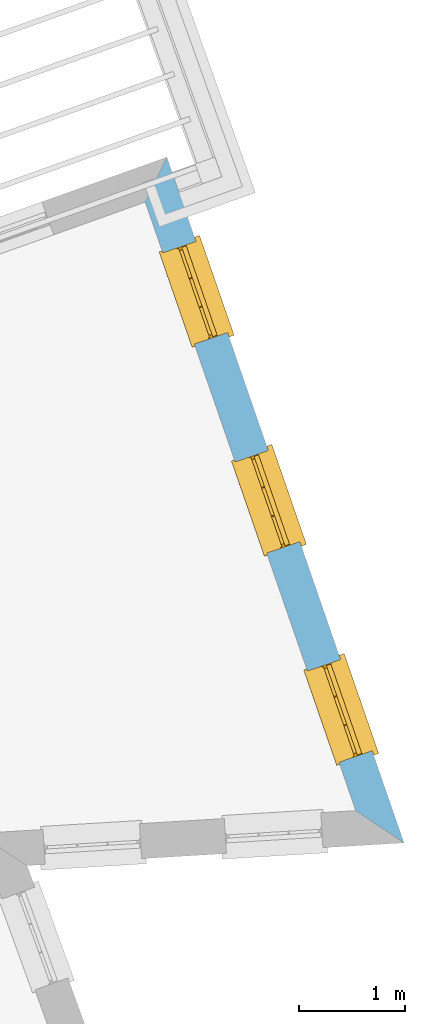
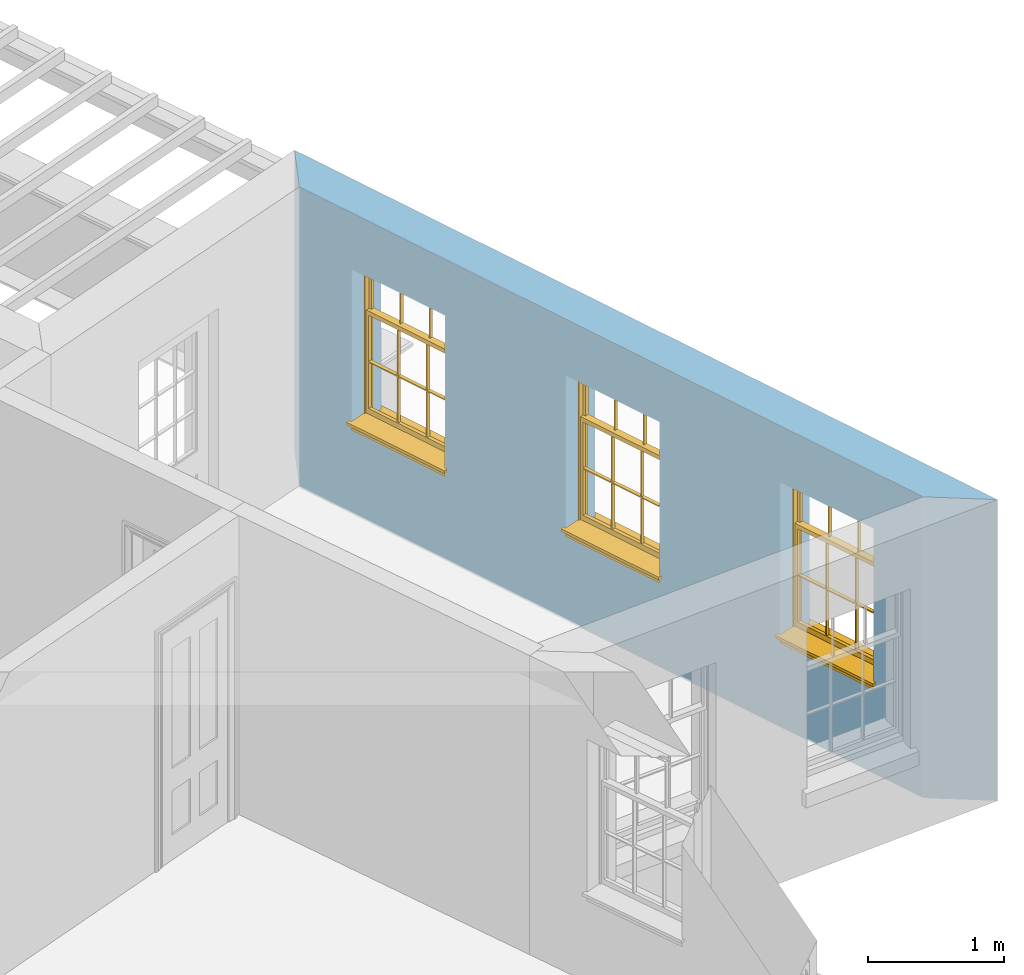
# One storey, part 7 of 12: 3 windows, 3 openings, plus 1 element that does not belong to this part.
"""IFC2X3 building model written with IfcOpenShell, lengths in metres."""

from ifc_helpers import new_model, si_unit, frame, origin, place, context, subcontext, project, spatial, polyline, outline, extrude, faceted_brep, material, layer, layer_set, layer_usage, element, fill, save


model = new_model("IFC2X3")

# Units and contexts
model_context = context("Model", 3, world=origin())
body_context = subcontext(model_context, "Body", "Model", "MODEL_VIEW")
ifc_project = project(units=[si_unit("PLANEANGLEUNIT", "RADIAN"), si_unit("MASSUNIT", "GRAM", prefix="KILO"), si_unit("FORCEUNIT", "NEWTON", prefix="KILO"), si_unit("LENGTHUNIT", "METRE")], contexts=[model_context])

# Site, building, storey
site_placement = place(None, origin())
site = spatial("IfcSite", under=ifc_project, at=site_placement, CompositionType="ELEMENT")
building_placement = place(None, origin())
building = spatial("IfcBuilding", under=site, at=building_placement, Name="Building plot-12", CompositionType="ELEMENT")
storey_placement = place(None, frame((0.0, 0.0, 6.45)))
storey = spatial("IfcBuildingStorey", under=building, at=storey_placement, Name="Floor 1", CompositionType="ELEMENT", Elevation=6.45)

# Wall, openings, windows
ifc_material = material(Name="Masonry")
ifc_layer = layer(ifc_material, 0.33, ventilated=False)
ifc_layer_set = layer_set([ifc_layer], Name="My Wall")
ifc_layer_usage = layer_usage(ifc_layer_set, "AXIS2", "NEGATIVE", 0.08)
wall_placement = place(storey_placement, origin())
wall = element("IfcWallStandardCase", 1, at=wall_placement, inside=storey, material=ifc_layer_usage, Name="exterior", context=body_context, shape_type="SweptSolid", body=[
    extrude(outline(polyline([(62.6036094343713, 35.0733568984167), (63.057647216937, 34.7701593682112), (60.8252944529976, 41.2249256313146), (60.6224114250311, 40.801918386454), (62.6036094343713, 35.0733568984167)])), origin(), (0.0, 0.0, 1.0), 2.7),
])
opening_1_placement = place(storey_placement, frame((0.0, 0.0, 0.75)))
opening_1 = element("IfcOpeningElement", 2, at=opening_1_placement, cuts=wall, Name="Opening", ObjectType="Opening", context=body_context, shape_type="SweptSolid", body=[
    extrude(outline(polyline([(62.7583178339086, 35.6356593171161), (62.4608839337952, 36.4956785465891), (62.1490088286017, 36.387817901493), (62.4464427287151, 35.52779867202), (62.7583178339086, 35.6356593171161)])), origin(), (0.0, 0.0, 1.0), 1.445),
])
opening_2_placement = place(storey_placement, frame((0.0, 0.0, 0.75)))
opening_2 = element("IfcOpeningElement", 3, at=opening_2_placement, cuts=wall, Name="Opening", ObjectType="Opening", context=body_context, shape_type="SweptSolid", body=[
    extrude(outline(polyline([(62.0776231637569, 37.6038630272753), (61.7801892636435, 38.4638822567483), (61.46831415845, 38.3560216116522), (61.7657480585634, 37.4960023821792), (62.0776231637569, 37.6038630272753)])), origin(), (0.0, 0.0, 1.0), 1.445),
])
opening_3_placement = place(storey_placement, frame((0.0, 0.0, 0.75)))
opening_3 = element("IfcOpeningElement", 4, at=opening_3_placement, cuts=wall, Name="Opening", ObjectType="Opening", context=body_context, shape_type="SweptSolid", body=[
    extrude(outline(polyline([(61.3969284936051, 39.5720667374345), (61.0994945934918, 40.4320859669075), (60.7876194882983, 40.3242253218114), (61.0850533884116, 39.4642060923384), (61.3969284936051, 39.5720667374345)])), origin(), (0.0, 0.0, 1.0), 1.445),
])
window_1_placement = place(storey_placement, frame((62.5220488148226, 35.5539467071948, 0.75), z_axis=(0.0, 0.0, 1.0), x_axis=(-0.297433900113383, 0.860019229473011, 0.0)))
window_1 = element("IfcWindow", 5, at=window_1_placement, inside=storey, Name="bedroom outside window", OverallHeight=1.445, OverallWidth=0.91, context=body_context, shape_type="Brep", held_by="IfcProductRepresentation", body=[
    faceted_brep([(0.876875, -0.105, 0.999097), (0.876875, -0.105, 1.411875), (0.9, -0.105, 1.435), (0.033125, -0.105, 1.411875), (0.033125, -0.105, 0.999097), (0.01, -0.105, 1.435), (0.033125, -0.135, 1.411875), (0.01, -0.135, 1.435), (0.033125, -0.135, 0.999097), (0.876875, -0.135, 1.411875), (0.876875, -0.135, 0.999097), (0.9, -0.135, 1.435), (0.033125, -0.105, 0.960972), (0.01, -0.105, 0.960972), (0.033125, -0.105, 0.548195), (0.876875, -0.105, 0.960972), (0.876875, -0.105, 0.548195), (0.9, -0.105, 0.960972), (0.876875, -0.105, 0.538195), (0.876875, -0.105, 0.125417), (0.9, -0.105, 0.077167), (0.033125, -0.105, 0.125417), (0.033125, -0.105, 0.538195), (0.01, -0.105, 0.077167), (0.9, -0.135, 0.960972), (0.01, -0.135, 0.960972), (-0.0425, -0.25, 0.01), (-0.0425, -0.3, 0.001667), (0.0, -0.25, 0.01), (0.9525, -0.25, 0.01), (0.91, -0.25, 0.01), (0.9525, -0.3, 0.001667), (-0.02, 0.08, 0.077167), (0.0, 0.08, 0.077167), (-0.02, 0.11, 0.077167), (0.0, -0.06, 0.077167), (0.01, -0.06, 0.077167), (0.91, -0.06, 0.077167), (0.91, 0.08, 0.077167), (0.9, -0.06, 0.077167), (0.93, 0.08, 0.077167), (0.93, 0.11, 0.077167), (0.01, -0.105, 0.999097), (0.01, -0.075, 0.999097), (0.9, -0.105, 0.999097), (0.9, -0.075, 0.999097), (0.876875, -0.075, 0.125417), (0.876875, -0.075, 0.538195), (0.9, -0.075, 0.077167), (0.876875, -0.075, 0.548195), (0.876875, -0.075, 0.960972), (0.033125, -0.075, 0.125417), (0.01, -0.075, 0.077167), (0.033125, -0.075, 0.538195), (0.033125, -0.075, 0.960972), (0.033125, -0.075, 0.548195), (-0.02, 0.08, 0.052167), (-0.02, 0.11, 0.052167), (0.93, 0.11, 0.052167), (0.93, 0.08, 0.052167), (0.91, 0.08, 0.052167), (0.0, 0.08, 0.052167), (0.91, -0.15, 0.026667), (0.0, -0.15, 0.026667), (-0.0425, -0.3, -0.123333), (0.9525, -0.3, -0.123333), (-0.0425, -0.25, -0.123333), (0.9525, -0.25, -0.123333), (0.01, -0.06, 1.435), (0.9, -0.06, 1.435), (0.0, -0.06, 1.445), (0.91, -0.06, 1.445), (0.01, -0.15, 0.077167), (0.9, -0.15, 0.077167), (0.592292, -0.105, 0.125417), (0.592292, -0.075, 0.125417), (0.317708, -0.075, 0.125417), (0.317708, -0.105, 0.125417), (0.592292, -0.105, 0.548195), (0.317708, -0.105, 0.548195), (0.317708, -0.105, 0.538195), (0.592292, -0.105, 0.538195), (0.592292, -0.075, 0.548195), (0.317708, -0.075, 0.548195), (0.602292, -0.075, 0.548195), (0.602292, -0.105, 0.548195), (0.317708, -0.075, 0.538195), (0.307708, -0.075, 0.125417), (0.307708, -0.075, 0.538195), (0.602292, -0.075, 0.538195), (0.602292, -0.075, 0.125417), (0.592292, -0.075, 0.538195), (0.307708, -0.075, 0.548195), (0.317708, -0.075, 0.960972), (0.307708, -0.075, 0.960972), (0.602292, -0.075, 0.960972), (0.592292, -0.075, 0.960972), (0.307708, -0.105, 0.538195), (0.307708, -0.105, 0.125417), (0.307708, -0.105, 0.548195), (0.307708, -0.105, 0.960972), (0.592292, -0.105, 0.960972), (0.317708, -0.105, 0.960972), (0.602292, -0.105, 0.960972), (0.602292, -0.105, 0.538195), (0.602292, -0.105, 0.125417), (0.317708, -0.135, 1.411875), (0.307708, -0.135, 1.411875), (0.307708, -0.135, 0.999097), (0.317708, -0.135, 0.999097), (0.602292, -0.135, 1.411875), (0.592292, -0.135, 1.411875), (0.592292, -0.135, 0.999097), (0.602292, -0.135, 0.999097), (0.317708, -0.105, 0.999097), (0.307708, -0.105, 0.999097), (0.307708, -0.105, 1.411875), (0.317708, -0.105, 1.411875), (0.602292, -0.105, 0.999097), (0.592292, -0.105, 0.999097), (0.592292, -0.105, 1.411875), (0.602292, -0.105, 1.411875), (0.91, -0.15, 1.445), (0.9, -0.15, 1.435), (0.01, -0.15, 1.435), (0.0, -0.15, 1.445), (0.91, -0.25, 0.0), (0.0, -0.25, 0.0), (0.91, 0.08, 0.0), (0.0, 0.08, 0.0)], [[[0, 1, 2]], [[3, 4, 5]], [[6, 7, 8]], [[9, 10, 11]], [[12, 13, 14]], [[15, 16, 17]], [[18, 19, 20]], [[21, 22, 23]], [[24, 15, 17]], [[13, 12, 25]], [[26, 27, 28]], [[29, 30, 31]], [[32, 33, 34]], [[35, 36, 33]], [[37, 38, 39]], [[40, 41, 38]], [[42, 4, 43]], [[44, 45, 0]], [[46, 47, 48]], [[49, 50, 45]], [[51, 52, 53]], [[54, 55, 43]], [[38, 33, 36, 39]], [[41, 34, 33, 38]], [[56, 32, 34, 57]], [[57, 34, 41, 58]], [[58, 41, 40, 59]], [[57, 58, 60, 61]], [[52, 48, 39, 36]], [[62, 63, 28, 30]], [[27, 31, 30, 28]], [[27, 64, 65, 31]], [[66, 67, 65, 64]], [[2, 5, 68, 69]], [[68, 70, 71, 69]], [[20, 23, 72, 73]], [[73, 72, 63, 62]], [[74, 75, 76, 77]], [[78, 79, 80, 81]], [[78, 82, 83, 79]], [[16, 49, 84, 85]], [[86, 76, 87, 88]], [[89, 90, 75, 91]], [[92, 88, 53, 55]], [[82, 91, 86, 83]], [[93, 83, 92, 94]], [[95, 84, 82, 96]], [[89, 84, 49, 47]], [[97, 88, 87, 98]], [[22, 53, 88, 97]], [[81, 91, 75, 74]], [[80, 86, 91, 81]], [[77, 76, 86, 80]], [[99, 92, 55, 14]], [[100, 94, 92, 99]], [[101, 96, 82, 78]], [[79, 83, 93, 102]], [[85, 84, 95, 103]], [[104, 89, 47, 18]], [[105, 90, 89, 104]], [[104, 18, 16, 85]], [[80, 97, 98, 77]], [[104, 81, 74, 105]], [[103, 101, 78, 85]], [[99, 14, 22, 97]], [[102, 100, 99, 79]], [[106, 107, 108, 109]], [[110, 111, 112, 113]], [[114, 115, 116, 117]], [[118, 119, 120, 121]], [[107, 116, 115, 108]], [[111, 120, 119, 112]], [[109, 114, 117, 106]], [[113, 118, 121, 110]], [[85, 78, 81, 104]], [[84, 89, 91, 82]], [[83, 86, 88, 92]], [[79, 99, 97, 80]], [[109, 112, 119, 114]], [[102, 93, 96, 101]], [[106, 117, 120, 111]], [[98, 87, 51, 21]], [[6, 3, 116, 107]], [[110, 121, 1, 9]], [[19, 46, 90, 105]], [[26, 66, 64, 27]], [[29, 31, 65, 67]], [[25, 24, 112, 109]], [[11, 7, 106, 111]], [[75, 48, 52, 76]], [[43, 45, 96, 93]], [[45, 43, 114, 119]], [[5, 2, 120, 117]], [[24, 25, 102, 101]], [[42, 5, 4]], [[2, 44, 0]], [[49, 45, 48, 47]], [[52, 43, 55, 53]], [[14, 13, 23, 22]], [[20, 17, 16, 18]], [[24, 11, 10]], [[25, 8, 7]], [[8, 4, 3, 6]], [[9, 1, 0, 10]], [[15, 50, 49, 16]], [[18, 47, 46, 19]], [[21, 51, 53, 22]], [[14, 55, 54, 12]], [[44, 2, 69, 45]], [[68, 5, 42, 43]], [[36, 35, 70, 68]], [[39, 69, 71, 37]], [[62, 122, 123, 73]], [[63, 72, 124, 125]], [[8, 108, 115, 4]], [[113, 10, 0, 118]], [[94, 100, 12, 54]], [[17, 20, 73, 24]], [[72, 23, 13, 25]], [[52, 36, 68, 43]], [[69, 39, 48, 45]], [[11, 24, 73, 123]], [[7, 124, 72, 25]], [[23, 77, 98]], [[98, 21, 23]], [[105, 74, 20]], [[20, 19, 105]], [[20, 74, 77, 23]], [[113, 112, 24]], [[24, 10, 113]], [[25, 109, 108]], [[108, 8, 25]], [[110, 9, 11]], [[11, 111, 110]], [[7, 6, 107]], [[107, 106, 7]], [[5, 117, 116]], [[116, 3, 5]], [[121, 120, 2]], [[2, 1, 121]], [[11, 123, 124, 7]], [[122, 125, 124, 123]], [[43, 93, 94]], [[94, 54, 43]], [[96, 45, 95]], [[50, 95, 45]], [[15, 103, 95, 50]], [[48, 75, 90]], [[90, 46, 48]], [[87, 76, 52]], [[52, 51, 87]], [[103, 15, 24]], [[24, 101, 103]], [[100, 102, 25]], [[25, 12, 100]], [[115, 114, 43]], [[43, 4, 115]], [[118, 0, 45]], [[45, 119, 118]], [[71, 70, 125, 122]], [[70, 35, 63, 125]], [[122, 62, 37, 71]], [[126, 67, 66, 127]], [[60, 58, 59]], [[38, 60, 59, 40]], [[61, 56, 57]], [[32, 56, 61, 33]], [[61, 60, 128, 129]], [[62, 60, 38, 37]], [[126, 128, 60, 62]], [[33, 61, 63, 35]], [[61, 129, 127, 63]], [[128, 126, 127, 129]], [[28, 127, 66, 26]], [[63, 127, 28]], [[29, 67, 126, 30]], [[30, 126, 62]]]),
])
fill(opening_1, window_1)
window_2_placement = place(storey_placement, frame((61.8413541446709, 37.522150417354, 0.75), z_axis=(0.0, 0.0, 1.0), x_axis=(-0.297433900113376, 0.860019229473004, 0.0)))
window_2 = element("IfcWindow", 6, at=window_2_placement, inside=storey, Name="bedroom outside window", OverallHeight=1.445, OverallWidth=0.91, context=body_context, shape_type="Brep", held_by="IfcProductRepresentation", body=[
    faceted_brep([(0.876875, -0.105, 0.999097), (0.876875, -0.105, 1.411875), (0.9, -0.105, 1.435), (0.033125, -0.105, 1.411875), (0.033125, -0.105, 0.999097), (0.01, -0.105, 1.435), (0.033125, -0.135, 1.411875), (0.01, -0.135, 1.435), (0.033125, -0.135, 0.999097), (0.876875, -0.135, 1.411875), (0.876875, -0.135, 0.999097), (0.9, -0.135, 1.435), (0.033125, -0.105, 0.960972), (0.01, -0.105, 0.960972), (0.033125, -0.105, 0.548195), (0.876875, -0.105, 0.960972), (0.876875, -0.105, 0.548195), (0.9, -0.105, 0.960972), (0.876875, -0.105, 0.538195), (0.876875, -0.105, 0.125417), (0.9, -0.105, 0.077167), (0.033125, -0.105, 0.125417), (0.033125, -0.105, 0.538195), (0.01, -0.105, 0.077167), (0.9, -0.135, 0.960972), (0.01, -0.135, 0.960972), (-0.0425, -0.25, 0.01), (-0.0425, -0.3, 0.001667), (0.0, -0.25, 0.01), (0.9525, -0.25, 0.01), (0.91, -0.25, 0.01), (0.9525, -0.3, 0.001667), (-0.02, 0.08, 0.077167), (0.0, 0.08, 0.077167), (-0.02, 0.11, 0.077167), (0.0, -0.06, 0.077167), (0.01, -0.06, 0.077167), (0.91, -0.06, 0.077167), (0.91, 0.08, 0.077167), (0.9, -0.06, 0.077167), (0.93, 0.08, 0.077167), (0.93, 0.11, 0.077167), (0.01, -0.105, 0.999097), (0.01, -0.075, 0.999097), (0.9, -0.105, 0.999097), (0.9, -0.075, 0.999097), (0.876875, -0.075, 0.125417), (0.876875, -0.075, 0.538195), (0.9, -0.075, 0.077167), (0.876875, -0.075, 0.548195), (0.876875, -0.075, 0.960972), (0.033125, -0.075, 0.125417), (0.01, -0.075, 0.077167), (0.033125, -0.075, 0.538195), (0.033125, -0.075, 0.960972), (0.033125, -0.075, 0.548195), (-0.02, 0.08, 0.052167), (-0.02, 0.11, 0.052167), (0.93, 0.11, 0.052167), (0.93, 0.08, 0.052167), (0.91, 0.08, 0.052167), (0.0, 0.08, 0.052167), (0.91, -0.15, 0.026667), (0.0, -0.15, 0.026667), (-0.0425, -0.3, -0.123333), (0.9525, -0.3, -0.123333), (-0.0425, -0.25, -0.123333), (0.9525, -0.25, -0.123333), (0.01, -0.06, 1.435), (0.9, -0.06, 1.435), (0.0, -0.06, 1.445), (0.91, -0.06, 1.445), (0.01, -0.15, 0.077167), (0.9, -0.15, 0.077167), (0.592292, -0.105, 0.125417), (0.592292, -0.075, 0.125417), (0.317708, -0.075, 0.125417), (0.317708, -0.105, 0.125417), (0.592292, -0.105, 0.548195), (0.317708, -0.105, 0.548195), (0.317708, -0.105, 0.538195), (0.592292, -0.105, 0.538195), (0.592292, -0.075, 0.548195), (0.317708, -0.075, 0.548195), (0.602292, -0.075, 0.548195), (0.602292, -0.105, 0.548195), (0.317708, -0.075, 0.538195), (0.307708, -0.075, 0.125417), (0.307708, -0.075, 0.538195), (0.602292, -0.075, 0.538195), (0.602292, -0.075, 0.125417), (0.592292, -0.075, 0.538195), (0.307708, -0.075, 0.548195), (0.317708, -0.075, 0.960972), (0.307708, -0.075, 0.960972), (0.602292, -0.075, 0.960972), (0.592292, -0.075, 0.960972), (0.307708, -0.105, 0.538195), (0.307708, -0.105, 0.125417), (0.307708, -0.105, 0.548195), (0.307708, -0.105, 0.960972), (0.592292, -0.105, 0.960972), (0.317708, -0.105, 0.960972), (0.602292, -0.105, 0.960972), (0.602292, -0.105, 0.538195), (0.602292, -0.105, 0.125417), (0.317708, -0.135, 1.411875), (0.307708, -0.135, 1.411875), (0.307708, -0.135, 0.999097), (0.317708, -0.135, 0.999097), (0.602292, -0.135, 1.411875), (0.592292, -0.135, 1.411875), (0.592292, -0.135, 0.999097), (0.602292, -0.135, 0.999097), (0.317708, -0.105, 0.999097), (0.307708, -0.105, 0.999097), (0.307708, -0.105, 1.411875), (0.317708, -0.105, 1.411875), (0.602292, -0.105, 0.999097), (0.592292, -0.105, 0.999097), (0.592292, -0.105, 1.411875), (0.602292, -0.105, 1.411875), (0.91, -0.15, 1.445), (0.9, -0.15, 1.435), (0.01, -0.15, 1.435), (0.0, -0.15, 1.445), (0.91, -0.25, 0.0), (0.0, -0.25, 0.0), (0.91, 0.08, 0.0), (0.0, 0.08, 0.0)], [[[0, 1, 2]], [[3, 4, 5]], [[6, 7, 8]], [[9, 10, 11]], [[12, 13, 14]], [[15, 16, 17]], [[18, 19, 20]], [[21, 22, 23]], [[24, 15, 17]], [[13, 12, 25]], [[26, 27, 28]], [[29, 30, 31]], [[32, 33, 34]], [[35, 36, 33]], [[37, 38, 39]], [[40, 41, 38]], [[42, 4, 43]], [[44, 45, 0]], [[46, 47, 48]], [[49, 50, 45]], [[51, 52, 53]], [[54, 55, 43]], [[38, 33, 36, 39]], [[41, 34, 33, 38]], [[56, 32, 34, 57]], [[57, 34, 41, 58]], [[58, 41, 40, 59]], [[57, 58, 60, 61]], [[52, 48, 39, 36]], [[62, 63, 28, 30]], [[27, 31, 30, 28]], [[27, 64, 65, 31]], [[66, 67, 65, 64]], [[2, 5, 68, 69]], [[68, 70, 71, 69]], [[20, 23, 72, 73]], [[73, 72, 63, 62]], [[74, 75, 76, 77]], [[78, 79, 80, 81]], [[78, 82, 83, 79]], [[16, 49, 84, 85]], [[86, 76, 87, 88]], [[89, 90, 75, 91]], [[92, 88, 53, 55]], [[82, 91, 86, 83]], [[93, 83, 92, 94]], [[95, 84, 82, 96]], [[89, 84, 49, 47]], [[97, 88, 87, 98]], [[22, 53, 88, 97]], [[81, 91, 75, 74]], [[80, 86, 91, 81]], [[77, 76, 86, 80]], [[99, 92, 55, 14]], [[100, 94, 92, 99]], [[101, 96, 82, 78]], [[79, 83, 93, 102]], [[85, 84, 95, 103]], [[104, 89, 47, 18]], [[105, 90, 89, 104]], [[104, 18, 16, 85]], [[80, 97, 98, 77]], [[104, 81, 74, 105]], [[103, 101, 78, 85]], [[99, 14, 22, 97]], [[102, 100, 99, 79]], [[106, 107, 108, 109]], [[110, 111, 112, 113]], [[114, 115, 116, 117]], [[118, 119, 120, 121]], [[107, 116, 115, 108]], [[111, 120, 119, 112]], [[109, 114, 117, 106]], [[113, 118, 121, 110]], [[85, 78, 81, 104]], [[84, 89, 91, 82]], [[83, 86, 88, 92]], [[79, 99, 97, 80]], [[109, 112, 119, 114]], [[102, 93, 96, 101]], [[106, 117, 120, 111]], [[98, 87, 51, 21]], [[6, 3, 116, 107]], [[110, 121, 1, 9]], [[19, 46, 90, 105]], [[26, 66, 64, 27]], [[29, 31, 65, 67]], [[25, 24, 112, 109]], [[11, 7, 106, 111]], [[75, 48, 52, 76]], [[43, 45, 96, 93]], [[45, 43, 114, 119]], [[5, 2, 120, 117]], [[24, 25, 102, 101]], [[42, 5, 4]], [[2, 44, 0]], [[49, 45, 48, 47]], [[52, 43, 55, 53]], [[14, 13, 23, 22]], [[20, 17, 16, 18]], [[24, 11, 10]], [[25, 8, 7]], [[8, 4, 3, 6]], [[9, 1, 0, 10]], [[15, 50, 49, 16]], [[18, 47, 46, 19]], [[21, 51, 53, 22]], [[14, 55, 54, 12]], [[44, 2, 69, 45]], [[68, 5, 42, 43]], [[36, 35, 70, 68]], [[39, 69, 71, 37]], [[62, 122, 123, 73]], [[63, 72, 124, 125]], [[8, 108, 115, 4]], [[113, 10, 0, 118]], [[94, 100, 12, 54]], [[17, 20, 73, 24]], [[72, 23, 13, 25]], [[52, 36, 68, 43]], [[69, 39, 48, 45]], [[11, 24, 73, 123]], [[7, 124, 72, 25]], [[23, 77, 98]], [[98, 21, 23]], [[105, 74, 20]], [[20, 19, 105]], [[20, 74, 77, 23]], [[113, 112, 24]], [[24, 10, 113]], [[25, 109, 108]], [[108, 8, 25]], [[110, 9, 11]], [[11, 111, 110]], [[7, 6, 107]], [[107, 106, 7]], [[5, 117, 116]], [[116, 3, 5]], [[121, 120, 2]], [[2, 1, 121]], [[11, 123, 124, 7]], [[122, 125, 124, 123]], [[43, 93, 94]], [[94, 54, 43]], [[96, 45, 95]], [[50, 95, 45]], [[15, 103, 95, 50]], [[48, 75, 90]], [[90, 46, 48]], [[87, 76, 52]], [[52, 51, 87]], [[103, 15, 24]], [[24, 101, 103]], [[100, 102, 25]], [[25, 12, 100]], [[115, 114, 43]], [[43, 4, 115]], [[118, 0, 45]], [[45, 119, 118]], [[71, 70, 125, 122]], [[70, 35, 63, 125]], [[122, 62, 37, 71]], [[126, 67, 66, 127]], [[60, 58, 59]], [[38, 60, 59, 40]], [[61, 56, 57]], [[32, 56, 61, 33]], [[61, 60, 128, 129]], [[62, 60, 38, 37]], [[126, 128, 60, 62]], [[33, 61, 63, 35]], [[61, 129, 127, 63]], [[128, 126, 127, 129]], [[28, 127, 66, 26]], [[63, 127, 28]], [[29, 67, 126, 30]], [[30, 126, 62]]]),
])
fill(opening_2, window_2)
window_3_placement = place(storey_placement, frame((61.1606594745192, 39.4903541275132, 0.75), z_axis=(0.0, 0.0, 1.0), x_axis=(-0.297433900113383, 0.860019229473011, 0.0)))
window_3 = element("IfcWindow", 7, at=window_3_placement, inside=storey, Name="bedroom outside window", OverallHeight=1.445, OverallWidth=0.91, context=body_context, shape_type="Brep", held_by="IfcProductRepresentation", body=[
    faceted_brep([(0.876875, -0.105, 0.999097), (0.876875, -0.105, 1.411875), (0.9, -0.105, 1.435), (0.033125, -0.105, 1.411875), (0.033125, -0.105, 0.999097), (0.01, -0.105, 1.435), (0.033125, -0.135, 1.411875), (0.01, -0.135, 1.435), (0.033125, -0.135, 0.999097), (0.876875, -0.135, 1.411875), (0.876875, -0.135, 0.999097), (0.9, -0.135, 1.435), (0.033125, -0.105, 0.960972), (0.01, -0.105, 0.960972), (0.033125, -0.105, 0.548195), (0.876875, -0.105, 0.960972), (0.876875, -0.105, 0.548195), (0.9, -0.105, 0.960972), (0.876875, -0.105, 0.538195), (0.876875, -0.105, 0.125417), (0.9, -0.105, 0.077167), (0.033125, -0.105, 0.125417), (0.033125, -0.105, 0.538195), (0.01, -0.105, 0.077167), (0.9, -0.135, 0.960972), (0.01, -0.135, 0.960972), (-0.0425, -0.25, 0.01), (-0.0425, -0.3, 0.001667), (0.0, -0.25, 0.01), (0.9525, -0.25, 0.01), (0.91, -0.25, 0.01), (0.9525, -0.3, 0.001667), (-0.02, 0.08, 0.077167), (0.0, 0.08, 0.077167), (-0.02, 0.11, 0.077167), (0.0, -0.06, 0.077167), (0.01, -0.06, 0.077167), (0.91, -0.06, 0.077167), (0.91, 0.08, 0.077167), (0.9, -0.06, 0.077167), (0.93, 0.08, 0.077167), (0.93, 0.11, 0.077167), (0.01, -0.105, 0.999097), (0.01, -0.075, 0.999097), (0.9, -0.105, 0.999097), (0.9, -0.075, 0.999097), (0.876875, -0.075, 0.125417), (0.876875, -0.075, 0.538195), (0.9, -0.075, 0.077167), (0.876875, -0.075, 0.548195), (0.876875, -0.075, 0.960972), (0.033125, -0.075, 0.125417), (0.01, -0.075, 0.077167), (0.033125, -0.075, 0.538195), (0.033125, -0.075, 0.960972), (0.033125, -0.075, 0.548195), (-0.02, 0.08, 0.052167), (-0.02, 0.11, 0.052167), (0.93, 0.11, 0.052167), (0.93, 0.08, 0.052167), (0.91, 0.08, 0.052167), (0.0, 0.08, 0.052167), (0.91, -0.15, 0.026667), (0.0, -0.15, 0.026667), (-0.0425, -0.3, -0.123333), (0.9525, -0.3, -0.123333), (-0.0425, -0.25, -0.123333), (0.9525, -0.25, -0.123333), (0.01, -0.06, 1.435), (0.9, -0.06, 1.435), (0.0, -0.06, 1.445), (0.91, -0.06, 1.445), (0.01, -0.15, 0.077167), (0.9, -0.15, 0.077167), (0.592292, -0.105, 0.125417), (0.592292, -0.075, 0.125417), (0.317708, -0.075, 0.125417), (0.317708, -0.105, 0.125417), (0.592292, -0.105, 0.548195), (0.317708, -0.105, 0.548195), (0.317708, -0.105, 0.538195), (0.592292, -0.105, 0.538195), (0.592292, -0.075, 0.548195), (0.317708, -0.075, 0.548195), (0.602292, -0.075, 0.548195), (0.602292, -0.105, 0.548195), (0.317708, -0.075, 0.538195), (0.307708, -0.075, 0.125417), (0.307708, -0.075, 0.538195), (0.602292, -0.075, 0.538195), (0.602292, -0.075, 0.125417), (0.592292, -0.075, 0.538195), (0.307708, -0.075, 0.548195), (0.317708, -0.075, 0.960972), (0.307708, -0.075, 0.960972), (0.602292, -0.075, 0.960972), (0.592292, -0.075, 0.960972), (0.307708, -0.105, 0.538195), (0.307708, -0.105, 0.125417), (0.307708, -0.105, 0.548195), (0.307708, -0.105, 0.960972), (0.592292, -0.105, 0.960972), (0.317708, -0.105, 0.960972), (0.602292, -0.105, 0.960972), (0.602292, -0.105, 0.538195), (0.602292, -0.105, 0.125417), (0.317708, -0.135, 1.411875), (0.307708, -0.135, 1.411875), (0.307708, -0.135, 0.999097), (0.317708, -0.135, 0.999097), (0.602292, -0.135, 1.411875), (0.592292, -0.135, 1.411875), (0.592292, -0.135, 0.999097), (0.602292, -0.135, 0.999097), (0.317708, -0.105, 0.999097), (0.307708, -0.105, 0.999097), (0.307708, -0.105, 1.411875), (0.317708, -0.105, 1.411875), (0.602292, -0.105, 0.999097), (0.592292, -0.105, 0.999097), (0.592292, -0.105, 1.411875), (0.602292, -0.105, 1.411875), (0.91, -0.15, 1.445), (0.9, -0.15, 1.435), (0.01, -0.15, 1.435), (0.0, -0.15, 1.445), (0.91, -0.25, 0.0), (0.0, -0.25, 0.0), (0.91, 0.08, 0.0), (0.0, 0.08, 0.0)], [[[0, 1, 2]], [[3, 4, 5]], [[6, 7, 8]], [[9, 10, 11]], [[12, 13, 14]], [[15, 16, 17]], [[18, 19, 20]], [[21, 22, 23]], [[24, 15, 17]], [[13, 12, 25]], [[26, 27, 28]], [[29, 30, 31]], [[32, 33, 34]], [[35, 36, 33]], [[37, 38, 39]], [[40, 41, 38]], [[42, 4, 43]], [[44, 45, 0]], [[46, 47, 48]], [[49, 50, 45]], [[51, 52, 53]], [[54, 55, 43]], [[38, 33, 36, 39]], [[41, 34, 33, 38]], [[56, 32, 34, 57]], [[57, 34, 41, 58]], [[58, 41, 40, 59]], [[57, 58, 60, 61]], [[52, 48, 39, 36]], [[62, 63, 28, 30]], [[27, 31, 30, 28]], [[27, 64, 65, 31]], [[66, 67, 65, 64]], [[2, 5, 68, 69]], [[68, 70, 71, 69]], [[20, 23, 72, 73]], [[73, 72, 63, 62]], [[74, 75, 76, 77]], [[78, 79, 80, 81]], [[78, 82, 83, 79]], [[16, 49, 84, 85]], [[86, 76, 87, 88]], [[89, 90, 75, 91]], [[92, 88, 53, 55]], [[82, 91, 86, 83]], [[93, 83, 92, 94]], [[95, 84, 82, 96]], [[89, 84, 49, 47]], [[97, 88, 87, 98]], [[22, 53, 88, 97]], [[81, 91, 75, 74]], [[80, 86, 91, 81]], [[77, 76, 86, 80]], [[99, 92, 55, 14]], [[100, 94, 92, 99]], [[101, 96, 82, 78]], [[79, 83, 93, 102]], [[85, 84, 95, 103]], [[104, 89, 47, 18]], [[105, 90, 89, 104]], [[104, 18, 16, 85]], [[80, 97, 98, 77]], [[104, 81, 74, 105]], [[103, 101, 78, 85]], [[99, 14, 22, 97]], [[102, 100, 99, 79]], [[106, 107, 108, 109]], [[110, 111, 112, 113]], [[114, 115, 116, 117]], [[118, 119, 120, 121]], [[107, 116, 115, 108]], [[111, 120, 119, 112]], [[109, 114, 117, 106]], [[113, 118, 121, 110]], [[85, 78, 81, 104]], [[84, 89, 91, 82]], [[83, 86, 88, 92]], [[79, 99, 97, 80]], [[109, 112, 119, 114]], [[102, 93, 96, 101]], [[106, 117, 120, 111]], [[98, 87, 51, 21]], [[6, 3, 116, 107]], [[110, 121, 1, 9]], [[19, 46, 90, 105]], [[26, 66, 64, 27]], [[29, 31, 65, 67]], [[25, 24, 112, 109]], [[11, 7, 106, 111]], [[75, 48, 52, 76]], [[43, 45, 96, 93]], [[45, 43, 114, 119]], [[5, 2, 120, 117]], [[24, 25, 102, 101]], [[42, 5, 4]], [[2, 44, 0]], [[49, 45, 48, 47]], [[52, 43, 55, 53]], [[14, 13, 23, 22]], [[20, 17, 16, 18]], [[24, 11, 10]], [[25, 8, 7]], [[8, 4, 3, 6]], [[9, 1, 0, 10]], [[15, 50, 49, 16]], [[18, 47, 46, 19]], [[21, 51, 53, 22]], [[14, 55, 54, 12]], [[44, 2, 69, 45]], [[68, 5, 42, 43]], [[36, 35, 70, 68]], [[39, 69, 71, 37]], [[62, 122, 123, 73]], [[63, 72, 124, 125]], [[8, 108, 115, 4]], [[113, 10, 0, 118]], [[94, 100, 12, 54]], [[17, 20, 73, 24]], [[72, 23, 13, 25]], [[52, 36, 68, 43]], [[69, 39, 48, 45]], [[11, 24, 73, 123]], [[7, 124, 72, 25]], [[23, 77, 98]], [[98, 21, 23]], [[105, 74, 20]], [[20, 19, 105]], [[20, 74, 77, 23]], [[113, 112, 24]], [[24, 10, 113]], [[25, 109, 108]], [[108, 8, 25]], [[110, 9, 11]], [[11, 111, 110]], [[7, 6, 107]], [[107, 106, 7]], [[5, 117, 116]], [[116, 3, 5]], [[121, 120, 2]], [[2, 1, 121]], [[11, 123, 124, 7]], [[122, 125, 124, 123]], [[43, 93, 94]], [[94, 54, 43]], [[96, 45, 95]], [[50, 95, 45]], [[15, 103, 95, 50]], [[48, 75, 90]], [[90, 46, 48]], [[87, 76, 52]], [[52, 51, 87]], [[103, 15, 24]], [[24, 101, 103]], [[100, 102, 25]], [[25, 12, 100]], [[115, 114, 43]], [[43, 4, 115]], [[118, 0, 45]], [[45, 119, 118]], [[71, 70, 125, 122]], [[70, 35, 63, 125]], [[122, 62, 37, 71]], [[126, 67, 66, 127]], [[60, 58, 59]], [[38, 60, 59, 40]], [[61, 56, 57]], [[32, 56, 61, 33]], [[61, 60, 128, 129]], [[62, 60, 38, 37]], [[126, 128, 60, 62]], [[33, 61, 63, 35]], [[61, 129, 127, 63]], [[128, 126, 127, 129]], [[28, 127, 66, 26]], [[63, 127, 28]], [[29, 67, 126, 30]], [[30, 126, 62]]]),
])
fill(opening_3, window_3)

save(model, "model.ifc")
